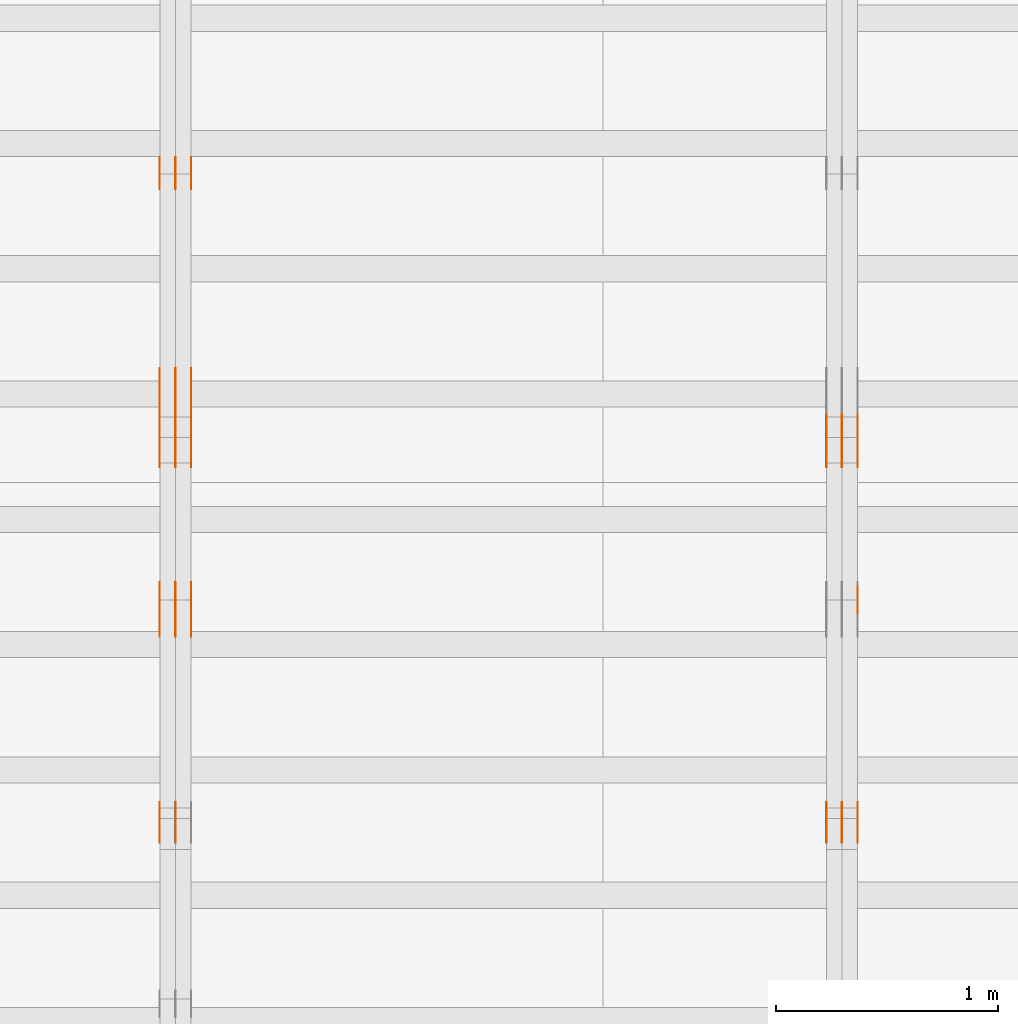
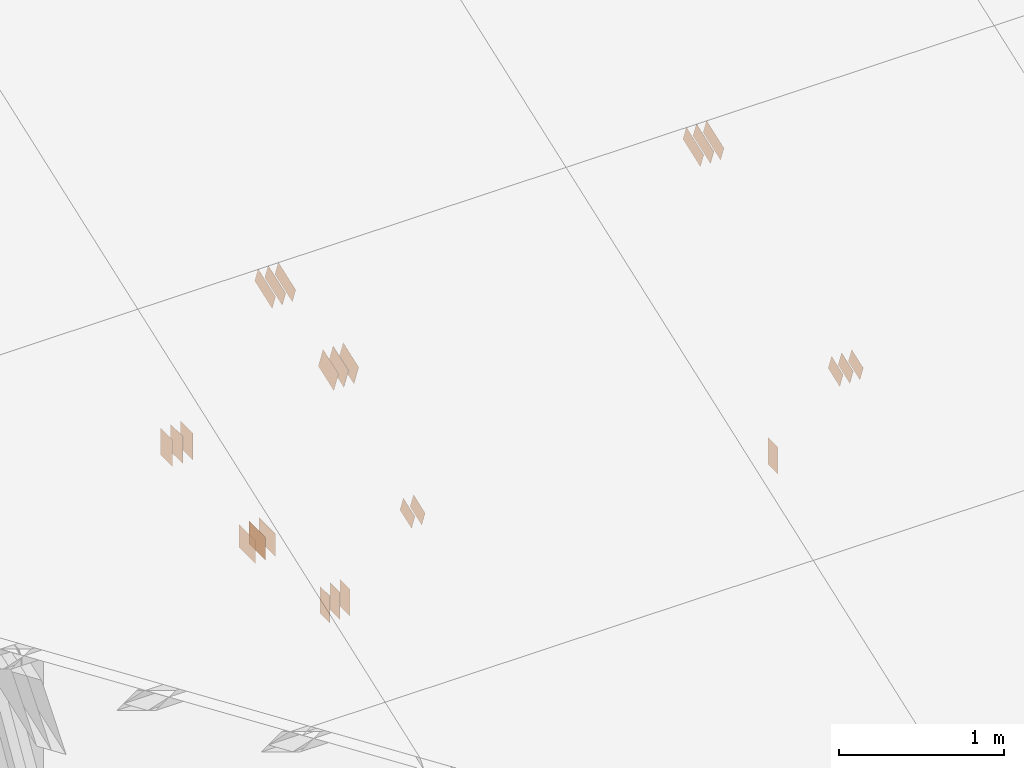
# One storey, part 92 of 189: 31 proxies.
"""IFC2X3 building model written with IfcOpenShell, lengths in millimetres."""

from ifc_helpers import new_model, entity, si_unit, converted_unit, derived_unit, direction, frame, frame_2d, origin, origin_2d_with_axis, place, context, subcontext, project, spatial, polyline, rectangle, outline, extrude, source, transform, mapped, material, type_object, type_shapes, element, save


model = new_model("IFC2X3")

# Units and contexts
model_context = context("Model", 3, precision=0.01, world=origin(), true_north=direction((6.12303176911189e-17, 1.0)))
body_context = subcontext(model_context, "Body", "Model", "MODEL_VIEW")
ifc_project = project(units=[si_unit("LENGTHUNIT", "METRE", prefix="MILLI"), si_unit("AREAUNIT", "SQUARE_METRE"), si_unit("VOLUMEUNIT", "CUBIC_METRE"), converted_unit("PLANEANGLEUNIT", "DEGREE", entity("IfcRatioMeasure", 0.0174532925199433), si_unit("PLANEANGLEUNIT", "RADIAN"), dimensions=[0, 0, 0, 0, 0, 0, 0]), si_unit("MASSUNIT", "GRAM", prefix="KILO"), derived_unit("MASSDENSITYUNIT", [(si_unit("MASSUNIT", "GRAM", prefix="KILO"), 1), (si_unit("LENGTHUNIT", "METRE"), -3)]), si_unit("TIMEUNIT", "SECOND"), si_unit("FREQUENCYUNIT", "HERTZ"), si_unit("THERMODYNAMICTEMPERATUREUNIT", "DEGREE_CELSIUS"), derived_unit("THERMALTRANSMITTANCEUNIT", [(si_unit("MASSUNIT", "GRAM", prefix="KILO"), 1), (si_unit("THERMODYNAMICTEMPERATUREUNIT", "KELVIN"), -1), (si_unit("TIMEUNIT", "SECOND"), -3)]), derived_unit("VOLUMETRICFLOWRATEUNIT", [(si_unit("LENGTHUNIT", "METRE"), 3), (si_unit("TIMEUNIT", "SECOND"), -1)]), si_unit("ELECTRICCURRENTUNIT", "AMPERE"), si_unit("ELECTRICVOLTAGEUNIT", "VOLT"), si_unit("POWERUNIT", "WATT"), si_unit("FORCEUNIT", "NEWTON"), si_unit("ILLUMINANCEUNIT", "LUX"), si_unit("LUMINOUSFLUXUNIT", "LUMEN"), si_unit("LUMINOUSINTENSITYUNIT", "CANDELA"), derived_unit("USERDEFINED", [(si_unit("MASSUNIT", "GRAM", prefix="KILO"), -1), (si_unit("LENGTHUNIT", "METRE"), -2), (si_unit("TIMEUNIT", "SECOND"), 3), (si_unit("LUMINOUSFLUXUNIT", "LUMEN"), 1)]), derived_unit("LINEARVELOCITYUNIT", [(si_unit("LENGTHUNIT", "METRE"), 1), (si_unit("TIMEUNIT", "SECOND"), -1)]), si_unit("PRESSUREUNIT", "PASCAL"), derived_unit("USERDEFINED", [(si_unit("LENGTHUNIT", "METRE"), -2), (si_unit("MASSUNIT", "GRAM", prefix="KILO"), 1), (si_unit("TIMEUNIT", "SECOND"), -2)])], contexts=[model_context])

# Site, building, storey
site_placement = place(None, origin())
site = spatial("IfcSite", under=ifc_project, at=site_placement, CompositionType="ELEMENT")
building_placement = place(site_placement, origin())
building = spatial("IfcBuilding", under=site, at=building_placement, CompositionType="ELEMENT")
storey_placement = place(building_placement, origin())
storey = spatial("IfcBuildingStorey", under=building, at=storey_placement, Name="Default", CompositionType="ELEMENT", Elevation=0.0)

# Proxies
ifc_material_1 = material(Name="IfcSurfaceStyle #154076")
building_element_proxy_type_1 = type_object("IfcBuildingElementProxyType", PredefinedType="NOTDEFINED", material=ifc_material_1)
shared_shape_1 = source(origin(), body_context, "Body", "SweptSolid", [
    extrude(outline(polyline([(-112.500654374667, -59.9999021691247), (112.500117969231, -59.9999021691247), (112.500612624162, 59.9999021691247), (-112.500076218726, 59.9999021691247), (-112.500654374667, -59.9999021691247)])), frame((112.500612624162, 60.0003514046321, 0.0), z_axis=(0.0, 0.0, 1.0), x_axis=(-1.0, 0.0, 0.0)), (0.0, 0.0, 1.0), 1.3),
])
type_shapes(building_element_proxy_type_1, [shared_shape_1])
proxy_1_placement = place(building_placement, frame((27301.3, 5418.0703125, 2162.37353515625), z_axis=(-1.0, 0.0, 0.0), x_axis=(0.0, 0.939692620785908, 0.342020143325669)))
element("IfcBuildingElementProxy", 1, at=proxy_1_placement, inside=storey, type_object=building_element_proxy_type_1, material=ifc_material_1, context=body_context, shape_type="MappedRepresentation", body=[
    mapped(shared_shape_1, transform((0.0, 0.0, 0.0), scale=1.0)),
])
ifc_material_2 = material(Name="IfcSurfaceStyle #154019")
building_element_proxy_type_2 = type_object("IfcBuildingElementProxyType", PredefinedType="NOTDEFINED", material=ifc_material_2)
shared_shape_2 = source(origin(), body_context, "Body", "SweptSolid", [
    extrude(outline(polyline([(-112.500654374667, -59.9999021691247), (112.500117969231, -59.9999021691247), (112.500612624162, 59.9999021691247), (-112.500076218726, 59.9999021691247), (-112.500654374667, -59.9999021691247)])), frame((112.500612624162, 60.0003514046321, 0.0), z_axis=(0.0, 0.0, 1.0), x_axis=(-1.0, 0.0, 0.0)), (0.0, 0.0, 1.0), 1.29999999999998),
])
type_shapes(building_element_proxy_type_2, [shared_shape_2])
proxy_2_placement = place(building_placement, frame((27230.0, 5418.0703125, 2162.37353515625), z_axis=(-1.0, 0.0, 0.0), x_axis=(0.0, 0.939692620785908, 0.342020143325669)))
element("IfcBuildingElementProxy", 2, at=proxy_2_placement, inside=storey, type_object=building_element_proxy_type_2, material=ifc_material_2, context=body_context, shape_type="MappedRepresentation", body=[
    mapped(shared_shape_2, transform((0.0, 0.0, 0.0), scale=1.0)),
])
ifc_material_3 = material(Name="IfcSurfaceStyle #153962")
building_element_proxy_type_3 = type_object("IfcBuildingElementProxyType", PredefinedType="NOTDEFINED", material=ifc_material_3)
shared_shape_3 = source(origin(), body_context, "Body", "SweptSolid", [
    extrude(outline(polyline([(-112.500654374667, -59.9999021691247), (112.500117969231, -59.9999021691247), (112.500612624162, 59.9999021691247), (-112.500076218726, 59.9999021691247), (-112.500654374667, -59.9999021691247)])), frame((112.500612624162, 60.0003514046321, 0.0), z_axis=(0.0, 0.0, 1.0), x_axis=(-1.0, 0.0, 0.0)), (0.0, 0.0, 1.0), 1.29999999999998),
])
type_shapes(building_element_proxy_type_3, [shared_shape_3])
proxy_3_placement = place(building_placement, frame((27231.3, 5418.0703125, 2162.37353515625), z_axis=(-1.0, 0.0, 0.0), x_axis=(0.0, 0.939692620785908, 0.342020143325669)))
element("IfcBuildingElementProxy", 3, at=proxy_3_placement, inside=storey, type_object=building_element_proxy_type_3, material=ifc_material_3, context=body_context, shape_type="MappedRepresentation", body=[
    mapped(shared_shape_3, transform((0.0, 0.0, 0.0), scale=1.0)),
])
ifc_material_4 = material(Name="IfcSurfaceStyle #153905")
building_element_proxy_type_4 = type_object("IfcBuildingElementProxyType", PredefinedType="NOTDEFINED", material=ifc_material_4)
shared_shape_4 = source(origin(), body_context, "Body", "SweptSolid", [
    extrude(outline(polyline([(-112.500654374667, -59.9999021691247), (112.500117969231, -59.9999021691247), (112.500612624162, 59.9999021691247), (-112.500076218726, 59.9999021691247), (-112.500654374667, -59.9999021691247)])), frame((112.500612624162, 60.0003514046321, 0.0), z_axis=(0.0, 0.0, 1.0), x_axis=(-1.0, 0.0, 0.0)), (0.0, 0.0, 1.0), 1.29999999999999),
])
type_shapes(building_element_proxy_type_4, [shared_shape_4])
proxy_4_placement = place(building_placement, frame((27160.0, 5418.0703125, 2162.37353515625), z_axis=(-1.0, 0.0, 0.0), x_axis=(0.0, 0.939692620785908, 0.342020143325669)))
element("IfcBuildingElementProxy", 4, at=proxy_4_placement, inside=storey, type_object=building_element_proxy_type_4, material=ifc_material_4, context=body_context, shape_type="MappedRepresentation", body=[
    mapped(shared_shape_4, transform((0.0, 0.0, 0.0), scale=1.0)),
])
ifc_material_5 = material(Name="IfcSurfaceStyle #153392")
building_element_proxy_type_5 = type_object("IfcBuildingElementProxyType", PredefinedType="NOTDEFINED", material=ifc_material_5)
shared_shape_5 = source(origin(), body_context, "Body", "SweptSolid", [
    extrude(rectangle(XDim=200.0, YDim=120.0, at=origin_2d_with_axis()), frame((100.0, 60.0, 0.0), z_axis=(0.0, 0.0, 1.0), x_axis=(-1.0, 0.0, 0.0)), (0.0, 0.0, 1.0), 1.3),
])
type_shapes(building_element_proxy_type_5, [shared_shape_5])
proxy_5_placement = place(building_placement, frame((27301.3, 4760.65625, 145.0), z_axis=(-1.0, 0.0, 0.0), x_axis=(0.0, 0.0, 1.0)))
element("IfcBuildingElementProxy", 5, at=proxy_5_placement, inside=storey, type_object=building_element_proxy_type_5, material=ifc_material_5, context=body_context, shape_type="MappedRepresentation", body=[
    mapped(shared_shape_5, transform((0.0, 0.0, 0.0), scale=1.0)),
])
ifc_material_6 = material(Name="IfcSurfaceStyle #153164")
building_element_proxy_type_6 = type_object("IfcBuildingElementProxyType", PredefinedType="NOTDEFINED", material=ifc_material_6)
shared_shape_6 = source(origin(), body_context, "Body", "SweptSolid", [
    extrude(outline(polyline([(-74.9994515581384, -59.9999039432178), (74.9998536965286, -59.9999039432178), (75.0003483514593, 59.9999039432178), (-75.0007504898495, 59.9999039432178), (-74.9994515581384, -59.9999039432178)])), frame((75.0003483514593, 60.0003496305408, 0.0), z_axis=(0.0, 0.0, 1.0), x_axis=(-1.0, 0.0, 0.0)), (0.0, 0.0, 1.0), 1.3),
])
type_shapes(building_element_proxy_type_6, [shared_shape_6])
proxy_6_placement = place(building_placement, frame((27301.3, 3726.8984375, 1559.607421875), z_axis=(-1.0, 0.0, 0.0), x_axis=(0.0, 0.939692620785908, 0.342020143325669)))
element("IfcBuildingElementProxy", 6, at=proxy_6_placement, inside=storey, type_object=building_element_proxy_type_6, material=ifc_material_6, context=body_context, shape_type="MappedRepresentation", body=[
    mapped(shared_shape_6, transform((0.0, 0.0, 0.0), scale=1.0)),
])
ifc_material_7 = material(Name="IfcSurfaceStyle #153107")
building_element_proxy_type_7 = type_object("IfcBuildingElementProxyType", PredefinedType="NOTDEFINED", material=ifc_material_7)
shared_shape_7 = source(origin(), body_context, "Body", "SweptSolid", [
    extrude(outline(polyline([(-74.9994515581384, -59.9999039432178), (74.9998536965286, -59.9999039432178), (75.0003483514593, 59.9999039432178), (-75.0007504898495, 59.9999039432178), (-74.9994515581384, -59.9999039432178)])), frame((75.0003483514593, 60.0003496305408, 0.0), z_axis=(0.0, 0.0, 1.0), x_axis=(-1.0, 0.0, 0.0)), (0.0, 0.0, 1.0), 1.29999999999999),
])
type_shapes(building_element_proxy_type_7, [shared_shape_7])
proxy_7_placement = place(building_placement, frame((27230.0, 3726.8984375, 1559.607421875), z_axis=(-1.0, 0.0, 0.0), x_axis=(0.0, 0.939692620785908, 0.342020143325669)))
element("IfcBuildingElementProxy", 7, at=proxy_7_placement, inside=storey, type_object=building_element_proxy_type_7, material=ifc_material_7, context=body_context, shape_type="MappedRepresentation", body=[
    mapped(shared_shape_7, transform((0.0, 0.0, 0.0), scale=1.0)),
])
ifc_material_8 = material(Name="IfcSurfaceStyle #153050")
building_element_proxy_type_8 = type_object("IfcBuildingElementProxyType", PredefinedType="NOTDEFINED", material=ifc_material_8)
shared_shape_8 = source(origin(), body_context, "Body", "SweptSolid", [
    extrude(outline(polyline([(-74.9994515581384, -59.9999039432178), (74.9998536965286, -59.9999039432178), (75.0003483514593, 59.9999039432178), (-75.0007504898495, 59.9999039432178), (-74.9994515581384, -59.9999039432178)])), frame((75.0003483514593, 60.0003496305408, 0.0), z_axis=(0.0, 0.0, 1.0), x_axis=(-1.0, 0.0, 0.0)), (0.0, 0.0, 1.0), 1.29999999999999),
])
type_shapes(building_element_proxy_type_8, [shared_shape_8])
proxy_8_placement = place(building_placement, frame((27231.3, 3726.8984375, 1559.607421875), z_axis=(-1.0, 0.0, 0.0), x_axis=(0.0, 0.939692620785908, 0.342020143325669)))
element("IfcBuildingElementProxy", 8, at=proxy_8_placement, inside=storey, type_object=building_element_proxy_type_8, material=ifc_material_8, context=body_context, shape_type="MappedRepresentation", body=[
    mapped(shared_shape_8, transform((0.0, 0.0, 0.0), scale=1.0)),
])
ifc_material_9 = material(Name="IfcSurfaceStyle #152993")
building_element_proxy_type_9 = type_object("IfcBuildingElementProxyType", PredefinedType="NOTDEFINED", material=ifc_material_9)
shared_shape_9 = source(origin(), body_context, "Body", "SweptSolid", [
    extrude(outline(polyline([(-74.9994515581384, -59.9999039432178), (74.9998536965286, -59.9999039432178), (75.0003483514593, 59.9999039432178), (-75.0007504898495, 59.9999039432178), (-74.9994515581384, -59.9999039432178)])), frame((75.0003483514593, 60.0003496305408, 0.0), z_axis=(0.0, 0.0, 1.0), x_axis=(-1.0, 0.0, 0.0)), (0.0, 0.0, 1.0), 1.29999999999999),
])
type_shapes(building_element_proxy_type_9, [shared_shape_9])
proxy_9_placement = place(building_placement, frame((27160.0, 3726.8984375, 1559.607421875), z_axis=(-1.0, 0.0, 0.0), x_axis=(0.0, 0.939692620785908, 0.342020143325669)))
element("IfcBuildingElementProxy", 9, at=proxy_9_placement, inside=storey, type_object=building_element_proxy_type_9, material=ifc_material_9, context=body_context, shape_type="MappedRepresentation", body=[
    mapped(shared_shape_9, transform((0.0, 0.0, 0.0), scale=1.0)),
])
ifc_material_10 = material(Name="IfcSurfaceStyle #142162")
building_element_proxy_type_10 = type_object("IfcBuildingElementProxyType", PredefinedType="NOTDEFINED", material=ifc_material_10)
shared_shape_10 = source(origin(), body_context, "Body", "SweptSolid", [
    extrude(rectangle(XDim=200.0, YDim=144.0, at=frame_2d((1.4210854715202e-14, 0.0), x_axis=(1.0, 0.0))), frame((100.0, 72.0, 0.0), z_axis=(0.0, 0.0, 1.0), x_axis=(-1.0, 0.0, 0.0)), (0.0, 0.0, 1.0), 1.3),
])
type_shapes(building_element_proxy_type_10, [shared_shape_10])
proxy_10_placement = place(building_placement, frame((24301.3, 6668.833984375, 145.0), z_axis=(-1.0, 0.0, 0.0), x_axis=(0.0, 0.0, 1.0)))
element("IfcBuildingElementProxy", 10, at=proxy_10_placement, inside=storey, type_object=building_element_proxy_type_10, material=ifc_material_10, context=body_context, shape_type="MappedRepresentation", body=[
    mapped(shared_shape_10, transform((0.0, 0.0, 0.0), scale=1.0)),
])
ifc_material_11 = material(Name="IfcSurfaceStyle #142105")
building_element_proxy_type_11 = type_object("IfcBuildingElementProxyType", PredefinedType="NOTDEFINED", material=ifc_material_11)
shared_shape_11 = source(origin(), body_context, "Body", "SweptSolid", [
    extrude(rectangle(XDim=200.0, YDim=144.0, at=frame_2d((1.4210854715202e-14, 0.0), x_axis=(1.0, 0.0))), frame((100.0, 72.0, 0.0), z_axis=(0.0, 0.0, 1.0), x_axis=(-1.0, 0.0, 0.0)), (0.0, 0.0, 1.0), 1.29999999999998),
])
type_shapes(building_element_proxy_type_11, [shared_shape_11])
proxy_11_placement = place(building_placement, frame((24230.0, 6668.833984375, 145.0), z_axis=(-1.0, 0.0, 0.0), x_axis=(0.0, 0.0, 1.0)))
element("IfcBuildingElementProxy", 11, at=proxy_11_placement, inside=storey, type_object=building_element_proxy_type_11, material=ifc_material_11, context=body_context, shape_type="MappedRepresentation", body=[
    mapped(shared_shape_11, transform((0.0, 0.0, 0.0), scale=1.0)),
])
ifc_material_12 = material(Name="IfcSurfaceStyle #142048")
building_element_proxy_type_12 = type_object("IfcBuildingElementProxyType", PredefinedType="NOTDEFINED", material=ifc_material_12)
shared_shape_12 = source(origin(), body_context, "Body", "SweptSolid", [
    extrude(rectangle(XDim=200.0, YDim=144.0, at=frame_2d((1.4210854715202e-14, 0.0), x_axis=(1.0, 0.0))), frame((100.0, 72.0, 0.0), z_axis=(0.0, 0.0, 1.0), x_axis=(-1.0, 0.0, 0.0)), (0.0, 0.0, 1.0), 1.29999999999998),
])
type_shapes(building_element_proxy_type_12, [shared_shape_12])
proxy_12_placement = place(building_placement, frame((24231.3, 6668.833984375, 145.0), z_axis=(-1.0, 0.0, 0.0), x_axis=(0.0, 0.0, 1.0)))
element("IfcBuildingElementProxy", 12, at=proxy_12_placement, inside=storey, type_object=building_element_proxy_type_12, material=ifc_material_12, context=body_context, shape_type="MappedRepresentation", body=[
    mapped(shared_shape_12, transform((0.0, 0.0, 0.0), scale=1.0)),
])
ifc_material_13 = material(Name="IfcSurfaceStyle #141991")
building_element_proxy_type_13 = type_object("IfcBuildingElementProxyType", PredefinedType="NOTDEFINED", material=ifc_material_13)
shared_shape_13 = source(origin(), body_context, "Body", "SweptSolid", [
    extrude(rectangle(XDim=200.0, YDim=144.0, at=frame_2d((1.4210854715202e-14, 0.0), x_axis=(1.0, 0.0))), frame((100.0, 72.0, 0.0), z_axis=(0.0, 0.0, 1.0), x_axis=(-1.0, 0.0, 0.0)), (0.0, 0.0, 1.0), 1.29999999999999),
])
type_shapes(building_element_proxy_type_13, [shared_shape_13])
proxy_13_placement = place(building_placement, frame((24160.0, 6668.833984375, 145.0), z_axis=(-1.0, 0.0, 0.0), x_axis=(0.0, 0.0, 1.0)))
element("IfcBuildingElementProxy", 13, at=proxy_13_placement, inside=storey, type_object=building_element_proxy_type_13, material=ifc_material_13, context=body_context, shape_type="MappedRepresentation", body=[
    mapped(shared_shape_13, transform((0.0, 0.0, 0.0), scale=1.0)),
])
ifc_material_14 = material(Name="IfcSurfaceStyle #141934")
building_element_proxy_type_14 = type_object("IfcBuildingElementProxyType", PredefinedType="NOTDEFINED", material=ifc_material_14)
shared_shape_14 = source(origin(), body_context, "Body", "SweptSolid", [
    extrude(rectangle(XDim=200.0, YDim=168.0, at=origin_2d_with_axis()), frame((100.0, 84.0, 0.0), z_axis=(0.0, 0.0, 1.0), x_axis=(-1.0, 0.0, 0.0)), (0.0, 0.0, 1.0), 1.3),
])
type_shapes(building_element_proxy_type_14, [shared_shape_14])
proxy_14_placement = place(building_placement, frame((24301.3, 5662.466796875, 206.5), z_axis=(-1.0, 0.0, 0.0), x_axis=(0.0, 1.0, 0.0)))
element("IfcBuildingElementProxy", 14, at=proxy_14_placement, inside=storey, type_object=building_element_proxy_type_14, material=ifc_material_14, context=body_context, shape_type="MappedRepresentation", body=[
    mapped(shared_shape_14, transform((0.0, 0.0, 0.0), scale=1.0)),
])
ifc_material_15 = material(Name="IfcSurfaceStyle #141877")
building_element_proxy_type_15 = type_object("IfcBuildingElementProxyType", PredefinedType="NOTDEFINED", material=ifc_material_15)
shared_shape_15 = source(origin(), body_context, "Body", "SweptSolid", [
    extrude(rectangle(XDim=200.0, YDim=168.0, at=origin_2d_with_axis()), frame((100.0, 84.0, 0.0), z_axis=(0.0, 0.0, 1.0), x_axis=(-1.0, 0.0, 0.0)), (0.0, 0.0, 1.0), 1.29999999999998),
])
type_shapes(building_element_proxy_type_15, [shared_shape_15])
proxy_15_placement = place(building_placement, frame((24230.0, 5662.466796875, 206.5), z_axis=(-1.0, 0.0, 0.0), x_axis=(0.0, 1.0, 0.0)))
element("IfcBuildingElementProxy", 15, at=proxy_15_placement, inside=storey, type_object=building_element_proxy_type_15, material=ifc_material_15, context=body_context, shape_type="MappedRepresentation", body=[
    mapped(shared_shape_15, transform((0.0, 0.0, 0.0), scale=1.0)),
])
ifc_material_16 = material(Name="IfcSurfaceStyle #141820")
building_element_proxy_type_16 = type_object("IfcBuildingElementProxyType", PredefinedType="NOTDEFINED", material=ifc_material_16)
shared_shape_16 = source(origin(), body_context, "Body", "SweptSolid", [
    extrude(rectangle(XDim=200.0, YDim=168.0, at=origin_2d_with_axis()), frame((100.0, 84.0, 0.0), z_axis=(0.0, 0.0, 1.0), x_axis=(-1.0, 0.0, 0.0)), (0.0, 0.0, 1.0), 1.29999999999998),
])
type_shapes(building_element_proxy_type_16, [shared_shape_16])
proxy_16_placement = place(building_placement, frame((24231.3, 5662.466796875, 206.5), z_axis=(-1.0, 0.0, 0.0), x_axis=(0.0, 1.0, 0.0)))
element("IfcBuildingElementProxy", 16, at=proxy_16_placement, inside=storey, type_object=building_element_proxy_type_16, material=ifc_material_16, context=body_context, shape_type="MappedRepresentation", body=[
    mapped(shared_shape_16, transform((0.0, 0.0, 0.0), scale=1.0)),
])
ifc_material_17 = material(Name="IfcSurfaceStyle #141763")
building_element_proxy_type_17 = type_object("IfcBuildingElementProxyType", PredefinedType="NOTDEFINED", material=ifc_material_17)
shared_shape_17 = source(origin(), body_context, "Body", "SweptSolid", [
    extrude(rectangle(XDim=200.0, YDim=168.0, at=origin_2d_with_axis()), frame((100.0, 84.0, 0.0), z_axis=(0.0, 0.0, 1.0), x_axis=(-1.0, 0.0, 0.0)), (0.0, 0.0, 1.0), 1.29999999999999),
])
type_shapes(building_element_proxy_type_17, [shared_shape_17])
proxy_17_placement = place(building_placement, frame((24160.0, 5662.466796875, 206.5), z_axis=(-1.0, 0.0, 0.0), x_axis=(0.0, 1.0, 0.0)))
element("IfcBuildingElementProxy", 17, at=proxy_17_placement, inside=storey, type_object=building_element_proxy_type_17, material=ifc_material_17, context=body_context, shape_type="MappedRepresentation", body=[
    mapped(shared_shape_17, transform((0.0, 0.0, 0.0), scale=1.0)),
])
ifc_material_18 = material(Name="IfcSurfaceStyle #138286")
building_element_proxy_type_18 = type_object("IfcBuildingElementProxyType", PredefinedType="NOTDEFINED", material=ifc_material_18)
shared_shape_18 = source(origin(), body_context, "Body", "SweptSolid", [
    extrude(outline(polyline([(-112.500654374667, -59.9999021691247), (112.500117969231, -59.9999021691247), (112.500612624162, 59.9999021691247), (-112.500076218726, 59.9999021691247), (-112.500654374667, -59.9999021691247)])), frame((112.500612624162, 60.0003514046321, 0.0), z_axis=(0.0, 0.0, 1.0), x_axis=(-1.0, 0.0, 0.0)), (0.0, 0.0, 1.0), 1.3),
])
type_shapes(building_element_proxy_type_18, [shared_shape_18])
proxy_18_placement = place(building_placement, frame((24301.3, 5418.0703125, 2162.37353515625), z_axis=(-1.0, 0.0, 0.0), x_axis=(0.0, 0.939692620785908, 0.342020143325669)))
element("IfcBuildingElementProxy", 18, at=proxy_18_placement, inside=storey, type_object=building_element_proxy_type_18, material=ifc_material_18, context=body_context, shape_type="MappedRepresentation", body=[
    mapped(shared_shape_18, transform((0.0, 0.0, 0.0), scale=1.0)),
])
ifc_material_19 = material(Name="IfcSurfaceStyle #138229")
building_element_proxy_type_19 = type_object("IfcBuildingElementProxyType", PredefinedType="NOTDEFINED", material=ifc_material_19)
shared_shape_19 = source(origin(), body_context, "Body", "SweptSolid", [
    extrude(outline(polyline([(-112.500654374667, -59.9999021691247), (112.500117969231, -59.9999021691247), (112.500612624162, 59.9999021691247), (-112.500076218726, 59.9999021691247), (-112.500654374667, -59.9999021691247)])), frame((112.500612624162, 60.0003514046321, 0.0), z_axis=(0.0, 0.0, 1.0), x_axis=(-1.0, 0.0, 0.0)), (0.0, 0.0, 1.0), 1.29999999999998),
])
type_shapes(building_element_proxy_type_19, [shared_shape_19])
proxy_19_placement = place(building_placement, frame((24230.0, 5418.0703125, 2162.37353515625), z_axis=(-1.0, 0.0, 0.0), x_axis=(0.0, 0.939692620785908, 0.342020143325669)))
element("IfcBuildingElementProxy", 19, at=proxy_19_placement, inside=storey, type_object=building_element_proxy_type_19, material=ifc_material_19, context=body_context, shape_type="MappedRepresentation", body=[
    mapped(shared_shape_19, transform((0.0, 0.0, 0.0), scale=1.0)),
])
ifc_material_20 = material(Name="IfcSurfaceStyle #138172")
building_element_proxy_type_20 = type_object("IfcBuildingElementProxyType", PredefinedType="NOTDEFINED", material=ifc_material_20)
shared_shape_20 = source(origin(), body_context, "Body", "SweptSolid", [
    extrude(outline(polyline([(-112.500654374667, -59.9999021691247), (112.500117969231, -59.9999021691247), (112.500612624162, 59.9999021691247), (-112.500076218726, 59.9999021691247), (-112.500654374667, -59.9999021691247)])), frame((112.500612624162, 60.0003514046321, 0.0), z_axis=(0.0, 0.0, 1.0), x_axis=(-1.0, 0.0, 0.0)), (0.0, 0.0, 1.0), 1.29999999999998),
])
type_shapes(building_element_proxy_type_20, [shared_shape_20])
proxy_20_placement = place(building_placement, frame((24231.3, 5418.0703125, 2162.37353515625), z_axis=(-1.0, 0.0, 0.0), x_axis=(0.0, 0.939692620785908, 0.342020143325669)))
element("IfcBuildingElementProxy", 20, at=proxy_20_placement, inside=storey, type_object=building_element_proxy_type_20, material=ifc_material_20, context=body_context, shape_type="MappedRepresentation", body=[
    mapped(shared_shape_20, transform((0.0, 0.0, 0.0), scale=1.0)),
])
ifc_material_21 = material(Name="IfcSurfaceStyle #138115")
building_element_proxy_type_21 = type_object("IfcBuildingElementProxyType", PredefinedType="NOTDEFINED", material=ifc_material_21)
shared_shape_21 = source(origin(), body_context, "Body", "SweptSolid", [
    extrude(outline(polyline([(-112.500654374667, -59.9999021691247), (112.500117969231, -59.9999021691247), (112.500612624162, 59.9999021691247), (-112.500076218726, 59.9999021691247), (-112.500654374667, -59.9999021691247)])), frame((112.500612624162, 60.0003514046321, 0.0), z_axis=(0.0, 0.0, 1.0), x_axis=(-1.0, 0.0, 0.0)), (0.0, 0.0, 1.0), 1.29999999999999),
])
type_shapes(building_element_proxy_type_21, [shared_shape_21])
proxy_21_placement = place(building_placement, frame((24160.0, 5418.0703125, 2162.37353515625), z_axis=(-1.0, 0.0, 0.0), x_axis=(0.0, 0.939692620785908, 0.342020143325669)))
element("IfcBuildingElementProxy", 21, at=proxy_21_placement, inside=storey, type_object=building_element_proxy_type_21, material=ifc_material_21, context=body_context, shape_type="MappedRepresentation", body=[
    mapped(shared_shape_21, transform((0.0, 0.0, 0.0), scale=1.0)),
])
ifc_material_22 = material(Name="IfcSurfaceStyle #137602")
building_element_proxy_type_22 = type_object("IfcBuildingElementProxyType", PredefinedType="NOTDEFINED", material=ifc_material_22)
shared_shape_22 = source(origin(), body_context, "Body", "SweptSolid", [
    extrude(rectangle(XDim=200.0, YDim=120.0, at=origin_2d_with_axis()), frame((100.0, 60.0, 0.0), z_axis=(0.0, 0.0, 1.0), x_axis=(-1.0, 0.0, 0.0)), (0.0, 0.0, 1.0), 1.3),
])
type_shapes(building_element_proxy_type_22, [shared_shape_22])
proxy_22_placement = place(building_placement, frame((24301.3, 4760.65625, 145.0), z_axis=(-1.0, 0.0, 0.0), x_axis=(0.0, 0.0, 1.0)))
element("IfcBuildingElementProxy", 22, at=proxy_22_placement, inside=storey, type_object=building_element_proxy_type_22, material=ifc_material_22, context=body_context, shape_type="MappedRepresentation", body=[
    mapped(shared_shape_22, transform((0.0, 0.0, 0.0), scale=1.0)),
])
ifc_material_23 = material(Name="IfcSurfaceStyle #137545")
building_element_proxy_type_23 = type_object("IfcBuildingElementProxyType", PredefinedType="NOTDEFINED", material=ifc_material_23)
shared_shape_23 = source(origin(), body_context, "Body", "SweptSolid", [
    extrude(rectangle(XDim=200.0, YDim=120.0, at=origin_2d_with_axis()), frame((100.0, 60.0, 0.0), z_axis=(0.0, 0.0, 1.0), x_axis=(-1.0, 0.0, 0.0)), (0.0, 0.0, 1.0), 1.29999999999998),
])
type_shapes(building_element_proxy_type_23, [shared_shape_23])
proxy_23_placement = place(building_placement, frame((24230.0, 4760.65625, 145.0), z_axis=(-1.0, 0.0, 0.0), x_axis=(0.0, 0.0, 1.0)))
element("IfcBuildingElementProxy", 23, at=proxy_23_placement, inside=storey, type_object=building_element_proxy_type_23, material=ifc_material_23, context=body_context, shape_type="MappedRepresentation", body=[
    mapped(shared_shape_23, transform((0.0, 0.0, 0.0), scale=1.0)),
])
ifc_material_24 = material(Name="IfcSurfaceStyle #137488")
building_element_proxy_type_24 = type_object("IfcBuildingElementProxyType", PredefinedType="NOTDEFINED", material=ifc_material_24)
shared_shape_24 = source(origin(), body_context, "Body", "SweptSolid", [
    extrude(rectangle(XDim=200.0, YDim=120.0, at=origin_2d_with_axis()), frame((100.0, 60.0, 0.0), z_axis=(0.0, 0.0, 1.0), x_axis=(-1.0, 0.0, 0.0)), (0.0, 0.0, 1.0), 1.29999999999998),
])
type_shapes(building_element_proxy_type_24, [shared_shape_24])
proxy_24_placement = place(building_placement, frame((24231.3, 4760.65625, 145.0), z_axis=(-1.0, 0.0, 0.0), x_axis=(0.0, 0.0, 1.0)))
element("IfcBuildingElementProxy", 24, at=proxy_24_placement, inside=storey, type_object=building_element_proxy_type_24, material=ifc_material_24, context=body_context, shape_type="MappedRepresentation", body=[
    mapped(shared_shape_24, transform((0.0, 0.0, 0.0), scale=1.0)),
])
ifc_material_25 = material(Name="IfcSurfaceStyle #137431")
building_element_proxy_type_25 = type_object("IfcBuildingElementProxyType", PredefinedType="NOTDEFINED", material=ifc_material_25)
shared_shape_25 = source(origin(), body_context, "Body", "SweptSolid", [
    extrude(rectangle(XDim=200.0, YDim=120.0, at=origin_2d_with_axis()), frame((100.0, 60.0, 0.0), z_axis=(0.0, 0.0, 1.0), x_axis=(-1.0, 0.0, 0.0)), (0.0, 0.0, 1.0), 1.29999999999999),
])
type_shapes(building_element_proxy_type_25, [shared_shape_25])
proxy_25_placement = place(building_placement, frame((24160.0, 4760.65625, 145.0), z_axis=(-1.0, 0.0, 0.0), x_axis=(0.0, 0.0, 1.0)))
element("IfcBuildingElementProxy", 25, at=proxy_25_placement, inside=storey, type_object=building_element_proxy_type_25, material=ifc_material_25, context=body_context, shape_type="MappedRepresentation", body=[
    mapped(shared_shape_25, transform((0.0, 0.0, 0.0), scale=1.0)),
])
ifc_material_26 = material(Name="IfcSurfaceStyle #137260")
building_element_proxy_type_26 = type_object("IfcBuildingElementProxyType", PredefinedType="NOTDEFINED", material=ifc_material_26)
shared_shape_26 = source(origin(), body_context, "Body", "SweptSolid", [
    extrude(outline(polyline([(-74.9994515581384, -59.9999039432178), (74.9998536965286, -59.9999039432178), (75.0003483514593, 59.9999039432178), (-75.0007504898495, 59.9999039432178), (-74.9994515581384, -59.9999039432178)])), frame((75.0003483514593, 60.0003496305408, 0.0), z_axis=(0.0, 0.0, 1.0), x_axis=(-1.0, 0.0, 0.0)), (0.0, 0.0, 1.0), 1.29999999999999),
])
type_shapes(building_element_proxy_type_26, [shared_shape_26])
proxy_26_placement = place(building_placement, frame((24231.3, 3726.8984375, 1559.607421875), z_axis=(-1.0, 0.0, 0.0), x_axis=(0.0, 0.939692620785908, 0.342020143325669)))
element("IfcBuildingElementProxy", 26, at=proxy_26_placement, inside=storey, type_object=building_element_proxy_type_26, material=ifc_material_26, context=body_context, shape_type="MappedRepresentation", body=[
    mapped(shared_shape_26, transform((0.0, 0.0, 0.0), scale=1.0)),
])
ifc_material_27 = material(Name="IfcSurfaceStyle #137203")
building_element_proxy_type_27 = type_object("IfcBuildingElementProxyType", PredefinedType="NOTDEFINED", material=ifc_material_27)
shared_shape_27 = source(origin(), body_context, "Body", "SweptSolid", [
    extrude(outline(polyline([(-74.9994515581384, -59.9999039432178), (74.9998536965286, -59.9999039432178), (75.0003483514593, 59.9999039432178), (-75.0007504898495, 59.9999039432178), (-74.9994515581384, -59.9999039432178)])), frame((75.0003483514593, 60.0003496305408, 0.0), z_axis=(0.0, 0.0, 1.0), x_axis=(-1.0, 0.0, 0.0)), (0.0, 0.0, 1.0), 1.29999999999999),
])
type_shapes(building_element_proxy_type_27, [shared_shape_27])
proxy_27_placement = place(building_placement, frame((24160.0, 3726.8984375, 1559.607421875), z_axis=(-1.0, 0.0, 0.0), x_axis=(0.0, 0.939692620785908, 0.342020143325669)))
element("IfcBuildingElementProxy", 27, at=proxy_27_placement, inside=storey, type_object=building_element_proxy_type_27, material=ifc_material_27, context=body_context, shape_type="MappedRepresentation", body=[
    mapped(shared_shape_27, transform((0.0, 0.0, 0.0), scale=1.0)),
])
ifc_material_28 = material(Name="IfcSurfaceStyle #132706")
building_element_proxy_type_28 = type_object("IfcBuildingElementProxyType", PredefinedType="NOTDEFINED", material=ifc_material_28)
shared_shape_28 = source(origin(), body_context, "Body", "SweptSolid", [
    extrude(outline(polyline([(-99.9993269270171, -84.0000832532405), (99.9997189122032, -84.0000832532405), (99.9992851765118, 84.0000832532405), (-99.999677161698, 84.0000832532405), (-99.9993269270171, -84.0000832532405)])), frame((99.9999283659736, 84.0000832532405, 0.0), z_axis=(0.0, 0.0, 1.0), x_axis=(-1.0, 0.0, 0.0)), (0.0, 0.0, 1.0), 1.3),
])
type_shapes(building_element_proxy_type_28, [shared_shape_28])
proxy_28_placement = place(building_placement, frame((24301.3, 4654.06379965055, 2052.96988554922), z_axis=(-1.0, 0.0, 0.0), x_axis=(0.0, 0.939692620785908, 0.342020143325669)))
element("IfcBuildingElementProxy", 28, at=proxy_28_placement, inside=storey, type_object=building_element_proxy_type_28, material=ifc_material_28, context=body_context, shape_type="MappedRepresentation", body=[
    mapped(shared_shape_28, transform((0.0, 0.0, 0.0), scale=1.0)),
])
ifc_material_29 = material(Name="IfcSurfaceStyle #132649")
building_element_proxy_type_29 = type_object("IfcBuildingElementProxyType", PredefinedType="NOTDEFINED", material=ifc_material_29)
shared_shape_29 = source(origin(), body_context, "Body", "SweptSolid", [
    extrude(outline(polyline([(-99.9993269270171, -84.0000832532405), (99.9997189122032, -84.0000832532405), (99.9992851765118, 84.0000832532405), (-99.999677161698, 84.0000832532405), (-99.9993269270171, -84.0000832532405)])), frame((99.9999283659736, 84.0000832532405, 0.0), z_axis=(0.0, 0.0, 1.0), x_axis=(-1.0, 0.0, 0.0)), (0.0, 0.0, 1.0), 1.29999999999998),
])
type_shapes(building_element_proxy_type_29, [shared_shape_29])
proxy_29_placement = place(building_placement, frame((24230.0, 4654.06379965055, 2052.96988554922), z_axis=(-1.0, 0.0, 0.0), x_axis=(0.0, 0.939692620785908, 0.342020143325669)))
element("IfcBuildingElementProxy", 29, at=proxy_29_placement, inside=storey, type_object=building_element_proxy_type_29, material=ifc_material_29, context=body_context, shape_type="MappedRepresentation", body=[
    mapped(shared_shape_29, transform((0.0, 0.0, 0.0), scale=1.0)),
])
ifc_material_30 = material(Name="IfcSurfaceStyle #132592")
building_element_proxy_type_30 = type_object("IfcBuildingElementProxyType", PredefinedType="NOTDEFINED", material=ifc_material_30)
shared_shape_30 = source(origin(), body_context, "Body", "SweptSolid", [
    extrude(outline(polyline([(-99.9993269270171, -84.0000832532405), (99.9997189122032, -84.0000832532405), (99.9992851765118, 84.0000832532405), (-99.999677161698, 84.0000832532405), (-99.9993269270171, -84.0000832532405)])), frame((99.9999283659736, 84.0000832532405, 0.0), z_axis=(0.0, 0.0, 1.0), x_axis=(-1.0, 0.0, 0.0)), (0.0, 0.0, 1.0), 1.29999999999998),
])
type_shapes(building_element_proxy_type_30, [shared_shape_30])
proxy_30_placement = place(building_placement, frame((24231.3, 4654.06379965055, 2052.96988554922), z_axis=(-1.0, 0.0, 0.0), x_axis=(0.0, 0.939692620785908, 0.342020143325669)))
element("IfcBuildingElementProxy", 30, at=proxy_30_placement, inside=storey, type_object=building_element_proxy_type_30, material=ifc_material_30, context=body_context, shape_type="MappedRepresentation", body=[
    mapped(shared_shape_30, transform((0.0, 0.0, 0.0), scale=1.0)),
])
ifc_material_31 = material(Name="IfcSurfaceStyle #132535")
building_element_proxy_type_31 = type_object("IfcBuildingElementProxyType", PredefinedType="NOTDEFINED", material=ifc_material_31)
shared_shape_31 = source(origin(), body_context, "Body", "SweptSolid", [
    extrude(outline(polyline([(-99.9993269270171, -84.0000832532405), (99.9997189122032, -84.0000832532405), (99.9992851765118, 84.0000832532405), (-99.999677161698, 84.0000832532405), (-99.9993269270171, -84.0000832532405)])), frame((99.9999283659736, 84.0000832532405, 0.0), z_axis=(0.0, 0.0, 1.0), x_axis=(-1.0, 0.0, 0.0)), (0.0, 0.0, 1.0), 1.29999999999999),
])
type_shapes(building_element_proxy_type_31, [shared_shape_31])
proxy_31_placement = place(building_placement, frame((24160.0, 4654.06379965055, 2052.96988554922), z_axis=(-1.0, 0.0, 0.0), x_axis=(0.0, 0.939692620785908, 0.342020143325669)))
element("IfcBuildingElementProxy", 31, at=proxy_31_placement, inside=storey, type_object=building_element_proxy_type_31, material=ifc_material_31, context=body_context, shape_type="MappedRepresentation", body=[
    mapped(shared_shape_31, transform((0.0, 0.0, 0.0), scale=1.0)),
])

save(model, "model.ifc")
